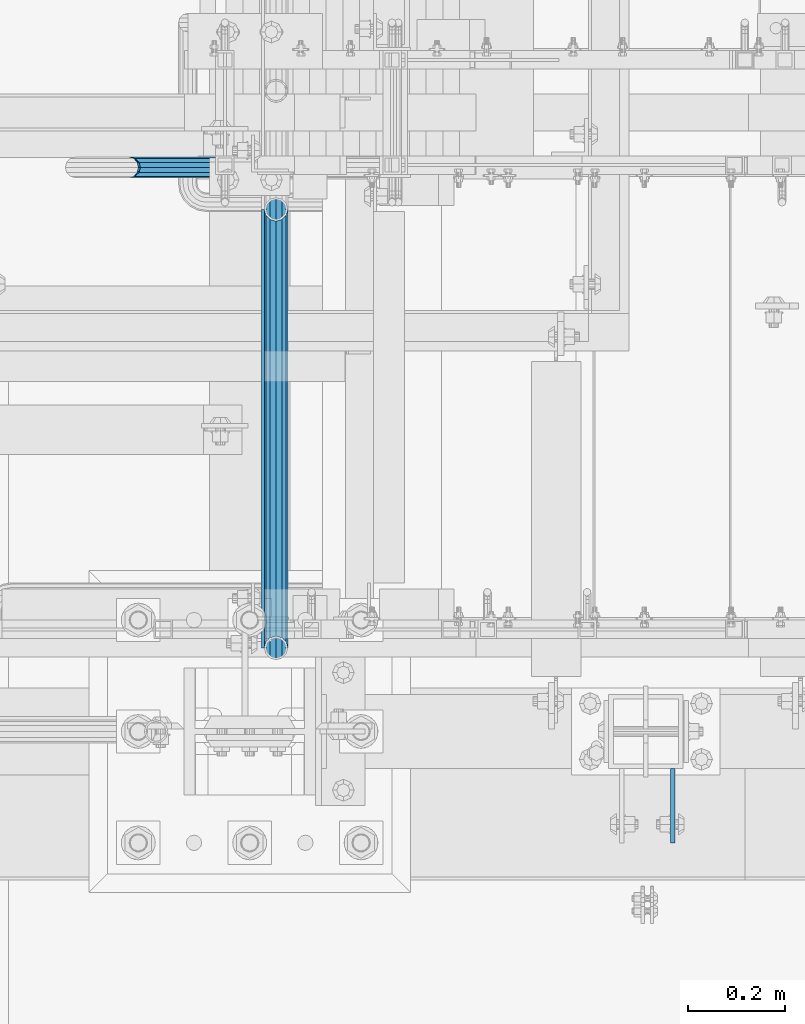
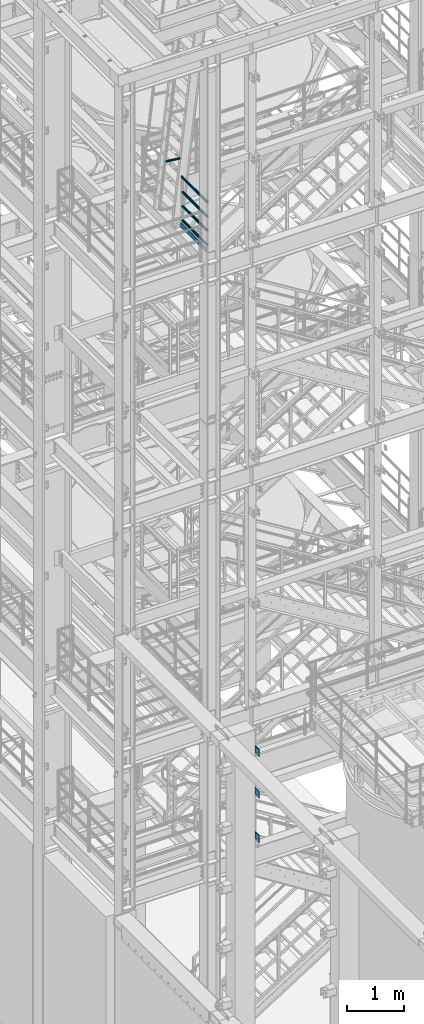
# One storey, part 1133 of 1876: 9 beams, 3 elements without a shape of their own.
"""IFC2X3 building model written with IfcOpenShell, lengths in millimetres."""

from ifc_helpers import new_model, si_unit, frame, origin_with_axes, place, context, subcontext, project, spatial, faceted_brep, material, type_object, element, aggregate, save


model = new_model("IFC2X3")

# Units and contexts
model_context = context("Model", 3, precision=1e-05, world=origin_with_axes())
body_context = subcontext(model_context, "Body", "Model", "MODEL_VIEW")
ifc_project = project(units=[si_unit("LENGTHUNIT", "METRE", prefix="MILLI"), si_unit("AREAUNIT", "SQUARE_METRE"), si_unit("VOLUMEUNIT", "CUBIC_METRE"), si_unit("MASSUNIT", "GRAM", prefix="KILO"), si_unit("TIMEUNIT", "SECOND"), si_unit("PLANEANGLEUNIT", "RADIAN"), si_unit("SOLIDANGLEUNIT", "STERADIAN"), si_unit("THERMODYNAMICTEMPERATUREUNIT", "DEGREE_CELSIUS"), si_unit("LUMINOUSINTENSITYUNIT", "LUMEN")], contexts=[model_context])

# Site, building, storey
site_placement = place(None, origin_with_axes())
site = spatial("IfcSite", under=ifc_project, at=site_placement, CompositionType="ELEMENT")
building_placement = place(site_placement, origin_with_axes())
building = spatial("IfcBuilding", under=site, at=building_placement, Name="Undefined", CompositionType="ELEMENT")
storey_placement = place(building_placement, origin_with_axes())
storey = spatial("IfcBuildingStorey", under=building, at=storey_placement, Name="Undefined", CompositionType="ELEMENT", Elevation=0.0)

# Assembly, beams
assembly_1_placement = place(storey_placement, origin_with_axes())
assembly_1 = element("IfcElementAssembly", 1, at=assembly_1_placement, inside=storey, Name="FRAME", AssemblyPlace="NOTDEFINED", PredefinedType="RIGID_FRAME")
ifc_material_1 = material(Name="STEEL/A36")
beam_type_1 = type_object("IfcBeamType", PredefinedType="NOTDEFINED")
beam_1_placement = place(assembly_1_placement, frame((2595.55129445271, -7188.2, 7226.3), z_axis=(0.0, 0.0, -1.0), x_axis=(0.0, -1.0, 0.0)))
beam_1 = element("IfcBeam", 2, at=beam_1_placement, type_object=beam_type_1, material=ifc_material_1, Name="PLATE", context=body_context, shape_type="Brep", body=[
    faceted_brep([(0.0, 4.76249999999982, -76.1999999999998), (3.63797880709171e-12, 4.76249999999982, 76.1999969482422), (152.399993896484, 4.76250000000073, 76.1999969482422), (152.4, 4.76249999999982, -76.1999999999998), (3.63797880709171e-12, -4.76249999999982, 76.1999969482422), (152.399993896484, -4.76250000000073, 76.1999969482422), (0.0, -4.76249999999982, -76.1999999999998), (152.4, -4.76249999999982, -76.1999999999998)], [[[0, 1, 2, 3]], [[4, 5, 2, 1]], [[4, 6, 7, 5]], [[6, 0, 3, 7]], [[5, 7, 3, 2]], [[6, 4, 1, 0]]]),
])
beam_2_placement = place(assembly_1_placement, frame((2595.55129445271, -7188.2, 6330.95), z_axis=(0.0, 0.0, -1.0), x_axis=(0.0, -1.0, 0.0)))
beam_2 = element("IfcBeam", 3, at=beam_2_placement, type_object=beam_type_1, material=ifc_material_1, Name="PLATE", context=body_context, shape_type="Brep", body=[
    faceted_brep([(0.0, 4.76249999999982, -76.1999999999998), (3.63797880709171e-12, 4.76249999999982, 76.1999969482422), (152.399993896484, 4.76250000000073, 76.1999969482422), (152.4, 4.76249999999982, -76.1999999999998), (3.63797880709171e-12, -4.76249999999982, 76.1999969482422), (152.399993896484, -4.76250000000073, 76.1999969482422), (0.0, -4.76249999999982, -76.1999999999998), (152.4, -4.76249999999982, -76.1999999999998)], [[[0, 1, 2, 3]], [[4, 5, 2, 1]], [[4, 6, 7, 5]], [[6, 0, 3, 7]], [[5, 7, 3, 2]], [[6, 4, 1, 0]]]),
])
beam_3_placement = place(assembly_1_placement, frame((2595.55129445271, -7188.2, 5384.8), z_axis=(0.0, 0.0, -1.0), x_axis=(0.0, -1.0, 0.0)))
beam_3 = element("IfcBeam", 4, at=beam_3_placement, type_object=beam_type_1, material=ifc_material_1, Name="PLATE", context=body_context, shape_type="Brep", body=[
    faceted_brep([(0.0, 4.76249999999982, -76.1999999999998), (3.63797880709171e-12, 4.76249999999982, 76.1999969482422), (152.399993896484, 4.76250000000073, 76.1999969482422), (152.4, 4.76249999999982, -76.1999999999998), (3.63797880709171e-12, -4.76249999999982, 76.1999969482422), (152.399993896484, -4.76250000000073, 76.1999969482422), (0.0, -4.76249999999982, -76.1999999999998), (152.4, -4.76249999999982, -76.1999999999998)], [[[0, 1, 2, 3]], [[4, 5, 2, 1]], [[4, 6, 7, 5]], [[6, 0, 3, 7]], [[5, 7, 3, 2]], [[6, 4, 1, 0]]]),
])
aggregate(assembly_1, [beam_1, beam_2, beam_3])

assembly_2_placement = place(storey_placement, origin_with_axes())
assembly_2 = element("IfcElementAssembly", 5, at=assembly_2_placement, inside=storey, Name="RAIL", AssemblyPlace="NOTDEFINED", PredefinedType="RIGID_FRAME")
ifc_material_2 = material()
beam_type_2 = type_object("IfcBeamType", Name="PIPE1-1/2SCH40", PredefinedType="NOTDEFINED")
beam_4_placement = place(assembly_2_placement, frame((1781.17499999997, -6040.755, 18145.125), z_axis=(0.0, 0.0, 1.0), x_axis=(0.0, -1.0, 0.0)))
beam_4 = element("IfcBeam", 6, at=beam_4_placement, type_object=beam_type_2, material=ifc_material_2, Name="RAIL", ObjectType="PIPE1-1/2SCH40", context=body_context, shape_type="Brep", body=[
    faceted_brep([(878.897807006677, -12.0650000000001, 20.8971929933177), (878.897807006677, -12.0649999999723, 15.8661214312087), (878.404378568823, -10.2235000000001, 17.7076214311819), (875.664999999995, 0.0, 20.4470000000001), (875.664999999995, 0.0, 24.130000000001), (878.404378568807, 10.2235000000001, 17.7076214311819), (878.897807006677, 12.0650000000278, 15.8661214311542), (878.897807006677, 12.0650000000001, 20.8971929933177), (899.794999999996, 24.1300000000001, 0.0), (887.729999999996, 20.8971929933184, 12.0649999999987), (887.729999999996, 20.8971929933184, -12.0649999999987), (884.540428437829, 17.7076214311803, 10.2235000000001), (887.279807006649, 20.4469999999999, 0.0), (884.540428437829, 17.7076214311803, -10.2235000000001), (878.897807006677, 12.0650000000278, -15.8661214311542), (878.897807006677, 12.0650000000001, -20.8971929933177), (878.404378568807, 10.2235000000001, -17.7076214311819), (875.664999999995, 0.0, -20.4470000000001), (875.664999999995, 0.0, -24.130000000001), (878.897807006677, -12.0649999999723, -15.8661214312087), (878.897807006677, -12.0650000000001, -20.8971929933177), (878.404378568823, -10.2235000000001, -17.7076214311819), (899.794999999996, -24.1299999999724, 0.0), (887.729999999996, -20.8971929933184, -12.0649999999987), (887.729999999996, -20.8971929933184, 12.0649999999987), (884.540428437886, -17.7076214311803, -10.2235000000001), (887.279807006705, -20.4469999999999, 0.0), (884.540428437886, -17.7076214311803, 10.2235000000001), (12.0650000000064, -20.8971929933177, -12.0649999999987), (20.8971929933249, -12.0650000000005, -20.8971929933177), (0.0, 24.1299999999992, 0.0), (12.0650000000064, 20.8971929933177, -12.0649999999987), (12.0650000000064, 20.8971929933177, 12.0649999999987), (20.8971929933249, 12.0650000000005, 20.8971929933177), (24.1300000000064, 0.0, 24.130000000001), (20.8971929933249, 12.0650000000005, -20.8971929933177), (24.1300000000063, 0.0, -24.130000000001), (24.1300000000063, 0.0, -20.4470000000001), (20.8971929933249, -12.0650000000005, -15.8661214311796), (21.3906214311868, -10.2235000000001, -17.7076214311819), (21.3906214311868, 10.2235000000001, -17.7076214311819), (20.8971929933249, 12.0650000000005, -15.8661214311796), (15.2545715621445, 17.7076214311801, -10.2235000000001), (12.5151929933249, 20.4470000000001, 0.0), (15.2545715621445, 17.7076214311801, 10.2235000000001), (20.8971929933249, 12.0650000000005, 15.8661214311796), (21.3906214311868, 10.2235000000001, 17.7076214311819), (24.1300000000064, 0.0, 20.4470000000001), (21.3906214311868, -10.2235000000001, 17.7076214311819), (20.8971929933249, -12.0650000000005, 15.8661214311796), (20.8971929933249, -12.0650000000005, 20.8971929933177), (12.0650000000064, -20.8971929933177, 12.0649999999987), (0.0, -24.1299999999992, 0.0), (15.2545715621445, -17.7076214311801, 10.2235000000001), (12.5151929933249, -20.4470000000001, 0.0), (15.2545715621445, -17.7076214311801, -10.2235000000001)], [[[0, 1, 2, 3, 4]], [[4, 3, 5, 6, 7]], [[8, 9, 10]], [[7, 6, 11, 12, 13, 14, 15, 10, 9]], [[16, 17, 18, 15, 14]], [[19, 20, 18, 17, 21]], [[22, 23, 24]], [[24, 23, 20, 19, 25, 26, 27, 1, 0]], [[28, 29, 20, 23]], [[30, 31, 32]], [[33, 34, 4, 7]], [[32, 33, 7, 9]], [[30, 32, 9, 8]], [[31, 30, 8, 10]], [[35, 31, 10, 15]], [[36, 35, 15, 18]], [[29, 36, 18, 20]], [[37, 36, 29, 38, 39]], [[40, 41, 35, 36, 37]], [[32, 31, 35, 41, 42, 43, 44, 45, 33]], [[33, 45, 46, 47, 34]], [[34, 47, 48, 49, 50]], [[34, 50, 0, 4]], [[50, 51, 24, 0]], [[51, 52, 22, 24]], [[52, 28, 23, 22]], [[51, 28, 52]], [[50, 49, 53, 54, 55, 38, 29, 28, 51]], [[55, 54, 26, 25]], [[21, 39, 38, 55, 25, 19]], [[37, 39, 21, 17]], [[40, 37, 17, 16]], [[42, 41, 40, 16, 14, 13]], [[43, 42, 13, 12]], [[44, 43, 12, 11]], [[5, 46, 45, 44, 11, 6]], [[47, 46, 5, 3]], [[48, 47, 3, 2]], [[53, 49, 48, 2, 1, 27]], [[54, 53, 27, 26]]]),
])
beam_5_placement = place(assembly_2_placement, frame((1781.17499999997, -6940.55, 18449.925), z_axis=(0.0, 0.0, -1.0), x_axis=(0.0, 1.0, 0.0)))
beam_5 = element("IfcBeam", 7, at=beam_5_placement, type_object=beam_type_2, material=ifc_material_2, Name="RAIL", ObjectType="PIPE1-1/2SCH40", context=body_context, shape_type="Brep", body=[
    faceted_brep([(0.0, 24.1299999999992, 0.0), (12.0650000000064, 20.8971929933177, -12.0649999999987), (12.0650000000064, 20.8971929933177, 12.0649999999987), (12.0650000000064, -20.8971929933177, 12.0649999999987), (12.0650000000064, -20.8971929933177, -12.0649999999987), (0.0, -24.1299999999992, 0.0), (20.8971929933249, -12.0650000000005, 20.8971929933177), (20.8971929933249, -12.0650000000005, 15.8661214311796), (15.2545715621445, -17.7076214311801, 10.2235000000001), (12.5151929933249, -20.4470000000001, 0.0), (15.2545715621445, -17.7076214311801, -10.2235000000001), (20.8971929933249, -12.0650000000005, -15.8661214311796), (20.8971929933249, -12.0650000000005, -20.8971929933177), (24.1300000000063, 0.0, -20.4470000000001), (24.1300000000063, 0.0, -24.130000000001), (21.3906214311868, -10.2235000000001, -17.7076214311819), (21.3906214311868, 10.2235000000001, -17.7076214311819), (20.8971929933249, 12.0650000000005, -15.8661214311796), (20.8971929933249, 12.0650000000005, -20.8971929933177), (15.2545715621445, 17.7076214311801, -10.2235000000001), (12.5151929933249, 20.4470000000001, 0.0), (15.2545715621445, 17.7076214311801, 10.2235000000001), (20.8971929933249, 12.0650000000005, 15.8661214311796), (20.8971929933249, 12.0650000000005, 20.8971929933177), (21.3906214311868, 10.2235000000001, 17.7076214311819), (24.1300000000064, 0.0, 20.4470000000001), (24.1300000000064, 0.0, 24.130000000001), (21.3906214311868, -10.2235000000001, 17.7076214311819), (899.794999999996, 24.1300000000001, 0.0), (887.729999999996, 20.8971929933184, -12.0649999999987), (878.897807006677, 12.0650000000001, -20.8971929933177), (899.794999999996, -24.1299999999724, 0.0), (887.729999999996, -20.8971929933184, -12.0649999999987), (887.729999999996, -20.8971929933184, 12.0649999999987), (878.897807006677, -12.0650000000001, 20.8971929933177), (878.897807006677, -12.0650000000001, -20.8971929933177), (875.664999999995, 0.0, -24.130000000001), (878.404378568807, 10.2235000000001, -17.7076214311819), (875.664999999995, 0.0, -20.4470000000001), (878.897807006677, 12.0650000000278, -15.8661214311542), (878.897807006677, -12.0649999999723, -15.8661214312087), (878.404378568823, -10.2235000000001, -17.7076214311819), (884.540428437886, -17.7076214311803, -10.2235000000001), (887.279807006705, -20.4469999999999, 0.0), (884.540428437886, -17.7076214311803, 10.2235000000001), (878.897807006677, -12.0649999999723, 15.8661214312087), (878.404378568823, -10.2235000000001, 17.7076214311819), (875.664999999995, 0.0, 20.4470000000001), (875.664999999995, 0.0, 24.130000000001), (878.897807006677, 12.0650000000001, 20.8971929933177), (887.729999999996, 20.8971929933184, 12.0649999999987), (878.897807006677, 12.0650000000278, 15.8661214311542), (884.540428437829, 17.7076214311803, 10.2235000000001), (887.279807006649, 20.4469999999999, 0.0), (884.540428437829, 17.7076214311803, -10.2235000000001), (878.404378568807, 10.2235000000001, 17.7076214311819)], [[[0, 1, 2]], [[3, 4, 5]], [[6, 7, 8, 9, 10, 11, 12, 4, 3]], [[13, 14, 12, 11, 15]], [[16, 17, 18, 14, 13]], [[2, 1, 18, 17, 19, 20, 21, 22, 23]], [[23, 22, 24, 25, 26]], [[26, 25, 27, 7, 6]], [[1, 0, 28, 29]], [[18, 1, 29, 30]], [[31, 32, 33]], [[6, 3, 33, 34]], [[3, 5, 31, 33]], [[5, 4, 32, 31]], [[4, 12, 35, 32]], [[12, 14, 36, 35]], [[14, 18, 30, 36]], [[37, 38, 36, 30, 39]], [[40, 35, 36, 38, 41]], [[33, 32, 35, 40, 42, 43, 44, 45, 34]], [[34, 45, 46, 47, 48]], [[26, 6, 34, 48]], [[2, 23, 49, 50]], [[23, 26, 48, 49]], [[0, 2, 50, 28]], [[28, 50, 29]], [[49, 51, 52, 53, 54, 39, 30, 29, 50]], [[48, 47, 55, 51, 49]], [[25, 24, 55, 47]], [[55, 24, 22, 21, 52, 51]], [[21, 20, 53, 52]], [[20, 19, 54, 53]], [[19, 17, 16, 37, 39, 54]], [[16, 13, 38, 37]], [[13, 15, 41, 38]], [[41, 15, 11, 10, 42, 40]], [[10, 9, 43, 42]], [[9, 8, 44, 43]], [[8, 7, 27, 46, 45, 44]], [[27, 25, 47, 46]]]),
])
beam_6_placement = place(assembly_2_placement, frame((1781.17499999997, -6940.55, 18754.725), z_axis=(0.0, 0.0, -1.0), x_axis=(0.0, 1.0, 0.0)))
beam_6 = element("IfcBeam", 8, at=beam_6_placement, type_object=beam_type_2, material=ifc_material_2, Name="RAIL", ObjectType="PIPE1-1/2SCH40", context=body_context, shape_type="Brep", body=[
    faceted_brep([(0.0, 24.1299999999992, 0.0), (12.0650000000064, 20.8971929933177, -12.0649999999987), (12.0650000000064, 20.8971929933177, 12.0649999999987), (12.0650000000064, -20.8971929933177, 12.0649999999987), (12.0650000000064, -20.8971929933177, -12.0649999999987), (0.0, -24.1299999999992, 0.0), (20.8971929933249, -12.0650000000005, 20.8971929933177), (20.8971929933249, -12.0650000000005, 15.8661214311796), (15.2545715621445, -17.7076214311801, 10.2235000000001), (12.5151929933249, -20.4470000000001, 0.0), (15.2545715621445, -17.7076214311801, -10.2235000000001), (20.8971929933249, -12.0650000000005, -15.8661214311796), (20.8971929933249, -12.0650000000005, -20.8971929933177), (24.1300000000063, 0.0, -20.4470000000001), (24.1300000000063, 0.0, -24.130000000001), (21.3906214311868, -10.2235000000001, -17.7076214311819), (21.3906214311868, 10.2235000000001, -17.7076214311819), (20.8971929933249, 12.0650000000005, -15.8661214311796), (20.8971929933249, 12.0650000000005, -20.8971929933177), (15.2545715621445, 17.7076214311801, -10.2235000000001), (12.5151929933249, 20.4470000000001, 0.0), (15.2545715621445, 17.7076214311801, 10.2235000000001), (20.8971929933249, 12.0650000000005, 15.8661214311796), (20.8971929933249, 12.0650000000005, 20.8971929933177), (21.3906214311868, 10.2235000000001, 17.7076214311819), (24.1300000000064, 0.0, 20.4470000000001), (24.1300000000064, 0.0, 24.130000000001), (21.3906214311868, -10.2235000000001, 17.7076214311819), (899.794999999996, 24.1300000000001, 0.0), (887.729999999996, 20.8971929933184, -12.0649999999987), (878.897807006677, 12.0650000000001, -20.8971929933177), (899.794999999996, -24.1299999999724, 0.0), (887.729999999996, -20.8971929933184, -12.0649999999987), (887.729999999996, -20.8971929933184, 12.0649999999987), (878.897807006677, -12.0650000000001, 20.8971929933177), (878.897807006677, -12.0650000000001, -20.8971929933177), (875.664999999995, 0.0, -24.130000000001), (878.404378568807, 10.2235000000001, -17.7076214311819), (875.664999999995, 0.0, -20.4470000000001), (878.897807006677, 12.0650000000278, -15.8661214311542), (878.897807006677, -12.0649999999723, -15.8661214312087), (878.404378568823, -10.2235000000001, -17.7076214311819), (884.540428437886, -17.7076214311803, -10.2235000000001), (887.279807006705, -20.4469999999999, 0.0), (884.540428437886, -17.7076214311803, 10.2235000000001), (878.897807006677, -12.0649999999723, 15.8661214312087), (878.404378568823, -10.2235000000001, 17.7076214311819), (875.664999999995, 0.0, 20.4470000000001), (875.664999999995, 0.0, 24.130000000001), (878.897807006677, 12.0650000000001, 20.8971929933177), (887.729999999996, 20.8971929933184, 12.0649999999987), (878.897807006677, 12.0650000000278, 15.8661214311542), (884.540428437829, 17.7076214311803, 10.2235000000001), (887.279807006649, 20.4469999999999, 0.0), (884.540428437829, 17.7076214311803, -10.2235000000001), (878.404378568807, 10.2235000000001, 17.7076214311819)], [[[0, 1, 2]], [[3, 4, 5]], [[6, 7, 8, 9, 10, 11, 12, 4, 3]], [[13, 14, 12, 11, 15]], [[16, 17, 18, 14, 13]], [[2, 1, 18, 17, 19, 20, 21, 22, 23]], [[23, 22, 24, 25, 26]], [[26, 25, 27, 7, 6]], [[1, 0, 28, 29]], [[18, 1, 29, 30]], [[31, 32, 33]], [[6, 3, 33, 34]], [[3, 5, 31, 33]], [[5, 4, 32, 31]], [[4, 12, 35, 32]], [[12, 14, 36, 35]], [[14, 18, 30, 36]], [[37, 38, 36, 30, 39]], [[40, 35, 36, 38, 41]], [[33, 32, 35, 40, 42, 43, 44, 45, 34]], [[34, 45, 46, 47, 48]], [[26, 6, 34, 48]], [[2, 23, 49, 50]], [[23, 26, 48, 49]], [[0, 2, 50, 28]], [[28, 50, 29]], [[49, 51, 52, 53, 54, 39, 30, 29, 50]], [[48, 47, 55, 51, 49]], [[25, 24, 55, 47]], [[55, 24, 22, 21, 52, 51]], [[21, 20, 53, 52]], [[20, 19, 54, 53]], [[19, 17, 16, 37, 39, 54]], [[16, 13, 38, 37]], [[13, 15, 41, 38]], [[41, 15, 11, 10, 42, 40]], [[10, 9, 43, 42]], [[9, 8, 44, 43]], [[8, 7, 27, 46, 45, 44]], [[27, 25, 47, 46]]]),
])
beam_7_placement = place(assembly_2_placement, frame((1781.17499999997, -6964.68, 19059.525), z_axis=(0.0, 0.0, -1.0), x_axis=(0.0, 1.0, 0.0)))
beam_7 = element("IfcBeam", 9, at=beam_7_placement, type_object=beam_type_2, material=ifc_material_2, Name="RAIL", ObjectType="PIPE1-1/2SCH40", context=body_context, shape_type="Brep", body=[
    faceted_brep([(24.1300000000001, -20.4469999999999, 0.0), (34.3535000000002, -17.7076214311803, 10.2235000000001), (913.701499999996, -17.7076214311803, 10.2235000000001), (923.924999999996, -20.4469999999999, 0.0), (41.8376214311802, -10.2235000000001, 17.7076214311819), (906.217378568816, -10.2235000000001, 17.7076214311819), (44.5770000000002, 0.0, 20.4470000000001), (903.477999999996, 0.0, 20.4470000000001), (41.8376214311802, 10.2235000000001, 17.7076214311819), (906.217378568816, 10.2235000000001, 17.7076214311819), (34.3535000000002, 17.7076214311803, 10.2235000000001), (913.701499999996, 17.7076214311803, 10.2235000000001), (24.1300000000001, 20.4469999999999, 0.0), (923.924999999996, 20.4469999999999, 0.0), (13.9065000000001, 17.7076214311803, -10.2235000000001), (934.148499999996, 17.7076214311803, -10.2235000000001), (6.42237856882002, 10.2235000000001, -17.7076214311819), (941.632621431176, 10.2235000000001, -17.7076214311819), (3.68299999999999, 0.0, -20.4470000000001), (944.371999999996, 0.0, -20.4470000000001), (6.42237856882002, -10.2235000000001, -17.7076214311819), (941.632621431176, -10.2235000000001, -17.7076214311819), (13.9065000000001, -17.7076214311803, -10.2235000000001), (934.148499999996, -17.7076214311803, -10.2235000000001), (24.1299999999854, -24.1299999999992, 0.0), (12.0650000000064, -20.8971929933177, -12.0649999999987), (935.989999999996, -20.8971929933184, -12.0649999999987), (923.924999999996, -24.1300000000001, 0.0), (3.23280700668147, -12.0650000000001, -20.8971929933177), (944.822192993314, -12.0650000000001, -20.8971929933177), (-1.45519152283669e-11, 0.0, -24.130000000001), (948.054999999996, 0.0, -24.130000000001), (3.23280700668147, 12.0650000000001, -20.8971929933177), (944.822192993314, 12.0650000000001, -20.8971929933177), (12.0650000000064, 20.8971929933177, -12.0649999999987), (935.989999999996, 20.8971929933184, -12.0649999999987), (24.1300000000047, 24.1299999999992, 0.0), (923.924999999996, 24.1300000000001, 0.0), (36.1949999999997, 20.8971929933184, 12.0649999999987), (911.859999999995, 20.8971929933184, 12.0649999999987), (45.0271929933187, 12.0650000000001, 20.8971929933177), (903.027807006677, 12.0650000000001, 20.8971929933177), (48.2600000000002, 0.0, 24.130000000001), (899.794999999996, 0.0, 24.130000000001), (45.0271929933187, -12.0650000000001, 20.8971929933177), (903.027807006677, -12.0650000000001, 20.8971929933177), (36.1949999999997, -20.8971929933184, 12.0649999999987), (911.859999999996, -20.8971929933184, 12.0649999999987)], [[[0, 1, 2, 3]], [[1, 4, 5, 2]], [[4, 6, 7, 5]], [[6, 8, 9, 7]], [[8, 10, 11, 9]], [[10, 12, 13, 11]], [[12, 14, 15, 13]], [[14, 16, 17, 15]], [[16, 18, 19, 17]], [[18, 20, 21, 19]], [[20, 22, 23, 21]], [[22, 0, 3, 23]], [[24, 25, 26, 27]], [[25, 28, 29, 26]], [[28, 30, 31, 29]], [[30, 32, 33, 31]], [[32, 34, 35, 33]], [[34, 36, 37, 35]], [[36, 38, 39, 37]], [[38, 40, 41, 39]], [[40, 42, 43, 41]], [[42, 44, 45, 43]], [[44, 46, 47, 45]], [[46, 24, 27, 47]], [[29, 31, 33, 35, 37, 39, 41, 43, 45, 47, 27, 26], [5, 7, 9, 11, 13, 15, 17, 19, 21, 23, 3, 2]], [[46, 44, 42, 40, 38, 36, 34, 32, 30, 28, 25, 24], [22, 20, 18, 16, 14, 12, 10, 8, 6, 4, 1, 0]]]),
])
beam_type_3 = type_object("IfcBeamType", PredefinedType="NOTDEFINED")
beam_8_placement = place(assembly_2_placement, frame((1754.1875, -6040.75500000001, 18049.875), z_axis=(0.0, 0.0, 1.0), x_axis=(0.0, -1.0, 0.0)))
beam_8 = element("IfcBeam", 10, at=beam_8_placement, type_object=beam_type_3, material=ifc_material_1, Name="PLATE", context=body_context, shape_type="Brep", body=[
    faceted_brep([(0.0, 3.17500000000018, -50.8000000000002), (0.0, 3.17500000000018, 50.8000000000002), (899.794999999988, 3.17499999999995, 50.7999999999993), (899.794999999988, 3.17499999999995, -50.7999999999993), (0.0, -3.17500000000018, 50.8000000000002), (899.794999999988, -3.17499999999995, 50.7999999999993), (0.0, -3.17500000000018, -50.8000000000002), (899.794999999988, -3.17499999999995, -50.7999999999993)], [[[0, 1, 2, 3]], [[1, 4, 5, 2]], [[4, 6, 7, 5]], [[6, 0, 3, 7]], [[5, 7, 3, 2]], [[6, 4, 1, 0]]]),
])
aggregate(assembly_2, [beam_8, beam_4, beam_5, beam_6, beam_7])

# Assembly, beam
assembly_3_placement = place(storey_placement, origin_with_axes())
assembly_3 = element("IfcElementAssembly", 11, at=assembly_3_placement, inside=storey, Name="RIGHT STRINGER", AssemblyPlace="NOTDEFINED", PredefinedType="RIGID_FRAME")
beam_type_4 = type_object("IfcBeamType", Name="PIPE1-1/4SCH40", PredefinedType="NOTDEFINED")
beam_9_placement = place(assembly_3_placement, frame((1479.94741760709, -5954.7125, 19446.6021544781), z_axis=(0.0, 1.0, 0.0), x_axis=(0.993502247476981, 0.0, -0.113812496054638)))
beam_9 = element("IfcBeam", 12, at=beam_9_placement, type_object=beam_type_4, material=ifc_material_2, Name="POST", ObjectType="PIPE1-1/4SCH40", context=body_context, shape_type="Brep", body=[
    faceted_brep([(0.0, 0.0, 21.0820000000003), (10.5410047402225, 10.5410000000047, 18.2575475625836), (10.5410000000002, -10.5410000000002, 18.2575475625836), (10.5410000000002, -10.5410000000002, -18.2575475625836), (10.5410047402225, 10.5410000000047, -18.2575475625836), (-4.28826751885936e-09, 0.0, -21.0820000000003), (18.2575475625836, -18.2575475625836, -10.5409999999993), (18.2575523716411, -13.3999612267653, -10.5410000000002), (13.6205911385651, -8.76300000002811, -15.1779612267264), (11.2725523401174, -1.09139364212751e-11, -17.5259999999998), (13.6205910882173, 8.76299999999537, -15.1779612267264), (18.2575522945893, 13.3999612267216, -10.5410000000002), (18.2575522806238, 18.2575475625817, -10.5410000000002), (21.0819999957121, 17.5259999907203, 0.0), (21.081999995713, 21.0819999907208, 0.0), (18.7339659606611, 15.1779612267237, -8.76299999999992), (18.7339659606627, 15.1779612267237, 8.76299999999992), (18.2575522945893, 13.3999612267216, 10.5410000000002), (18.2575522806238, 18.2575475625817, 10.5410000000002), (13.6205910882217, 8.76299999999537, 15.1779612267264), (11.2725523401217, -1.09139364212751e-11, 17.5259999999998), (13.6205911385692, -8.76300000002811, 15.1779612267264), (18.2575523716411, -13.3999612267653, 10.5410000000002), (18.2575475625836, -18.2575475625836, 10.5409999999993), (18.7339660478675, -15.177961226771, 8.76299999999992), (21.0819999957121, -17.5260000092794, 0.0), (21.0819999957121, -21.0820000092799, 0.0), (18.7339660478659, -15.177961226771, -8.76299999999992), (304.800009609033, -10.5410000004813, -18.2575475625836), (304.800009609034, -18.2575475630765, -10.5410000000002), (304.800009609031, -4.69299266114831e-10, -21.0820000000003), (304.800009609029, 10.5409999995427, -18.2575475625836), (304.800009609028, 18.2575475621416, -10.5410000000002), (304.800009609028, 21.0819999995583, 0.0), (304.800009609028, 18.2575475621416, 10.5410000000002), (304.800009609029, 10.5409999995427, 18.2575475625836), (304.800009609031, -4.69299266114831e-10, 21.0820000000003), (304.800009609033, -10.5410000004813, 18.2575475625836), (304.800009609034, -18.2575475630765, 10.5410000000002), (304.800009609035, -21.0820000004969, 0.0), (304.800009609033, -8.76300000047922, 15.1779612267264), (304.800009609031, -4.69299266114831e-10, 17.5259999999998), (304.800009609029, 8.76299999954426, 15.1779612267264), (304.800009609029, 15.1779612262762, 8.76299999999992), (304.800009609028, 17.5259999995542, 0.0), (304.800009609029, 15.1779612262762, -8.76299999999992), (304.800009609029, 8.76299999954426, -15.1779612267264), (304.800009609031, -4.69299266114831e-10, -17.5259999999998), (304.800009609033, -8.76300000047922, -15.1779612267264), (304.800009609034, -15.1779612272148, -8.76299999999992), (304.800009609034, -17.5260000004928, 0.0), (304.800009609034, -15.1779612272148, 8.76299999999992)], [[[0, 1, 2]], [[3, 4, 5]], [[6, 7, 8, 9, 10, 11, 12, 4, 3]], [[13, 14, 12, 11, 15]], [[16, 17, 18, 14, 13]], [[2, 1, 18, 17, 19, 20, 21, 22, 23]], [[23, 22, 24, 25, 26]], [[26, 25, 27, 7, 6]], [[28, 29, 6, 3]], [[30, 28, 3, 5]], [[31, 30, 5, 4]], [[32, 31, 4, 12]], [[33, 32, 12, 14]], [[34, 33, 14, 18]], [[35, 34, 18, 1]], [[36, 35, 1, 0]], [[37, 36, 0, 2]], [[38, 37, 2, 23]], [[39, 38, 23, 26]], [[29, 39, 26, 6]], [[28, 30, 31, 32, 33, 34, 35, 36, 37, 38, 39, 29], [40, 41, 42, 43, 44, 45, 46, 47, 48, 49, 50, 51]], [[51, 50, 25, 24]], [[21, 40, 51, 24, 22]], [[41, 40, 21, 20]], [[42, 41, 20, 19]], [[43, 42, 19, 17, 16]], [[44, 43, 16, 13]], [[45, 44, 13, 15]], [[10, 46, 45, 15, 11]], [[47, 46, 10, 9]], [[48, 47, 9, 8]], [[49, 48, 8, 7, 27]], [[50, 49, 27, 25]]]),
])
aggregate(assembly_3, [beam_9])

save(model, "model.ifc")
